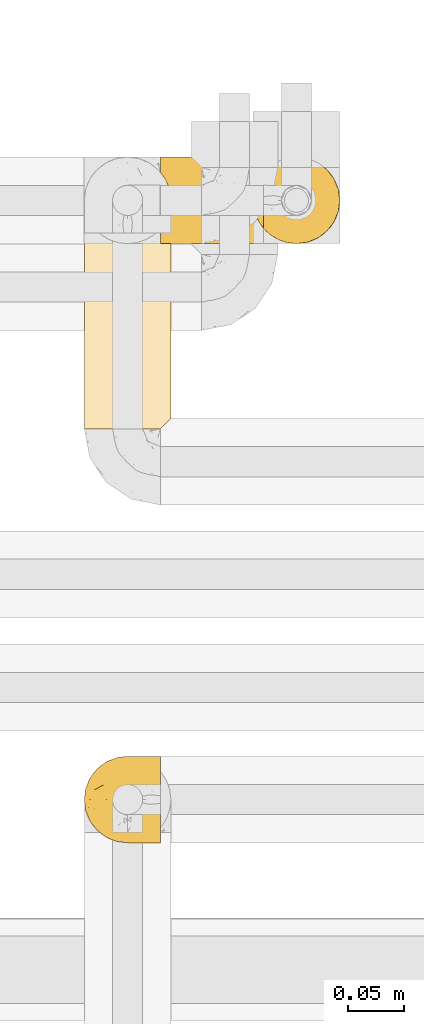
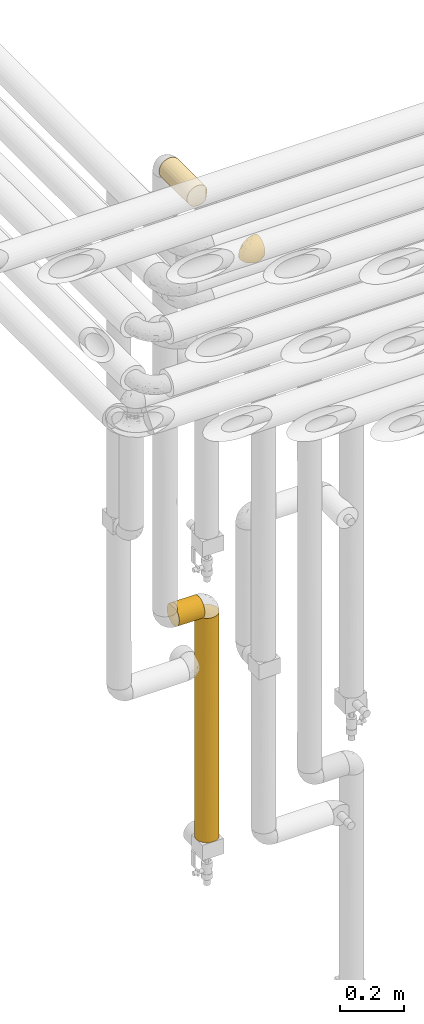
# One storey, part 291 of 827: 4 coverings.
"""IFC2X3 building model written with IfcOpenShell, lengths in millimetres."""

from ifc_helpers import new_model, entity, si_unit, converted_unit, derived_unit, direction, frame, origin, place, context, subcontext, project, spatial, faceted_brep, element, save


model = new_model("IFC2X3")

# Units and contexts
model_context = context("Model", 3, precision=0.01, world=origin(), true_north=direction((6.12303176911189e-17, 1.0)))
body_context = subcontext(model_context, "Body", "Model", "MODEL_VIEW")
ifc_project = project(units=[si_unit("LENGTHUNIT", "METRE", prefix="MILLI"), si_unit("AREAUNIT", "SQUARE_METRE"), si_unit("VOLUMEUNIT", "CUBIC_METRE"), converted_unit("PLANEANGLEUNIT", "DEGREE", entity("IfcRatioMeasure", 0.0174532925199433), si_unit("PLANEANGLEUNIT", "RADIAN"), dimensions=[0, 0, 0, 0, 0, 0, 0]), si_unit("MASSUNIT", "GRAM", prefix="KILO"), derived_unit("MASSDENSITYUNIT", [(si_unit("MASSUNIT", "GRAM", prefix="KILO"), 1), (si_unit("LENGTHUNIT", "METRE"), -3)]), derived_unit("MOMENTOFINERTIAUNIT", [(si_unit("LENGTHUNIT", "METRE"), 4)]), si_unit("TIMEUNIT", "SECOND"), si_unit("FREQUENCYUNIT", "HERTZ"), si_unit("THERMODYNAMICTEMPERATUREUNIT", "DEGREE_CELSIUS"), derived_unit("THERMALTRANSMITTANCEUNIT", [(si_unit("MASSUNIT", "GRAM", prefix="KILO"), 1), (si_unit("THERMODYNAMICTEMPERATUREUNIT", "KELVIN"), -1), (si_unit("TIMEUNIT", "SECOND"), -3)]), derived_unit("VOLUMETRICFLOWRATEUNIT", [(si_unit("LENGTHUNIT", "METRE"), 3), (si_unit("TIMEUNIT", "SECOND"), -1)]), derived_unit("MASSFLOWRATEUNIT", [(si_unit("MASSUNIT", "GRAM", prefix="KILO"), 1), (si_unit("TIMEUNIT", "SECOND"), -1)]), derived_unit("ROTATIONALFREQUENCYUNIT", [(si_unit("TIMEUNIT", "SECOND"), -1)]), si_unit("ELECTRICCURRENTUNIT", "AMPERE"), si_unit("ELECTRICVOLTAGEUNIT", "VOLT"), si_unit("POWERUNIT", "WATT"), si_unit("FORCEUNIT", "NEWTON", prefix="KILO"), si_unit("ILLUMINANCEUNIT", "LUX"), si_unit("LUMINOUSFLUXUNIT", "LUMEN"), si_unit("LUMINOUSINTENSITYUNIT", "CANDELA"), derived_unit("USERDEFINED", [(si_unit("MASSUNIT", "GRAM", prefix="KILO"), -1), (si_unit("LENGTHUNIT", "METRE"), -2), (si_unit("TIMEUNIT", "SECOND"), 3), (si_unit("LUMINOUSFLUXUNIT", "LUMEN"), 1)]), derived_unit("LINEARVELOCITYUNIT", [(si_unit("LENGTHUNIT", "METRE"), 1), (si_unit("TIMEUNIT", "SECOND"), -1)]), si_unit("PRESSUREUNIT", "PASCAL"), derived_unit("USERDEFINED", [(si_unit("LENGTHUNIT", "METRE"), -2), (si_unit("MASSUNIT", "GRAM", prefix="KILO"), 1), (si_unit("TIMEUNIT", "SECOND"), -2)]), derived_unit("LINEARFORCEUNIT", [(si_unit("MASSUNIT", "GRAM", prefix="KILO"), 1), (si_unit("LENGTHUNIT", "METRE"), 1), (si_unit("TIMEUNIT", "SECOND"), -2), (si_unit("LENGTHUNIT", "METRE"), -1)]), derived_unit("PLANARFORCEUNIT", [(si_unit("MASSUNIT", "GRAM", prefix="KILO"), 1), (si_unit("LENGTHUNIT", "METRE"), 1), (si_unit("TIMEUNIT", "SECOND"), -2), (si_unit("LENGTHUNIT", "METRE"), -2)])], contexts=[model_context])

# Site, building, storey
site_placement = place(None, origin())
site = spatial("IfcSite", under=ifc_project, at=site_placement, CompositionType="ELEMENT")
building_placement = place(site_placement, origin())
building = spatial("IfcBuilding", under=site, at=building_placement, CompositionType="ELEMENT")
storey_placement = place(building_placement, frame((0.0, 0.0, 28200.0)))
storey = spatial("IfcBuildingStorey", under=building, at=storey_placement, Name="08", CompositionType="ELEMENT", Elevation=28200.0)

# Coverings
covering_1_placement = place(storey_placement, frame((34952.84, 15249.95, 2969.3)))
element("IfcCovering", 1, at=covering_1_placement, inside=storey, Name=":ADSK_", ObjectType=":ADSK_", PredefinedType="INSULATION", context=body_context, shape_type="Brep", body=[
    faceted_brep([(69.15, 74.68, 47.38), (69.15, 70.1, 54.67), (69.15, 64.01, 60.76), (69.15, 56.72, 65.34), (69.15, 48.6, 68.18), (69.15, 40.05, 69.15), (69.15, 31.49, 68.18), (69.15, 23.36, 65.33), (69.15, 16.07, 60.75), (69.15, 9.98, 54.66), (69.15, 5.4, 47.37), (69.15, 2.56, 39.25), (69.15, 1.6, 30.7), (69.15, 2.46, 22.59), (69.15, 5.01, 14.86), (69.15, 9.13, 7.84), (69.15, 14.62, 1.85), (69.15, 16.82, 1.85), (69.15, 18.56, 1.85), (69.15, 20.52, 1.85), (69.15, 22.49, 1.85), (69.15, 24.46, 1.85), (69.15, 26.42, 1.85), (69.15, 28.39, 1.85), (69.15, 30.36, 1.85), (69.15, 32.55, 1.85), (69.15, 34.75, 1.85), (69.15, 36.94, 1.85), (69.15, 39.13, 1.85), (69.15, 41.33, 1.85), (69.15, 43.52, 1.85), (69.15, 45.72, 1.85), (69.15, 47.91, 1.85), (69.15, 50.11, 1.85), (69.15, 52.3, 1.85), (69.15, 54.49, 1.85), (69.15, 56.69, 1.85), (69.15, 58.88, 1.85), (69.15, 61.08, 1.85), (69.15, 63.27, 1.85), (69.15, 65.47, 1.85), (69.15, 70.97, 7.85), (69.15, 75.09, 14.88), (69.15, 77.64, 22.61), (69.15, 78.5, 30.7), (69.15, 77.53, 39.26), (68.89, 14.62, 1.6), (62.89, 9.12, 1.6), (55.87, 5.0, 1.6), (48.14, 2.46, 1.6), (40.05, 1.6, 1.6), (30.09, 2.91, 1.6), (20.82, 6.75, 1.6), (12.86, 12.86, 1.6), (6.75, 20.82, 1.6), (2.91, 30.09, 1.6), (1.6, 40.05, 1.6), (2.91, 50.0, 1.6), (6.75, 59.27, 1.6), (12.86, 67.23, 1.6), (20.82, 73.34, 1.6), (30.09, 77.19, 1.6), (40.05, 78.5, 1.6), (48.14, 77.63, 1.6), (55.87, 75.09, 1.6), (62.89, 70.97, 1.6), (68.89, 65.47, 1.6), (68.89, 63.27, 1.6), (68.89, 62.29, 1.6), (68.89, 60.7, 1.6), (68.89, 59.11, 1.6), (68.89, 57.52, 1.6), (68.89, 55.93, 1.6), (68.89, 54.34, 1.6), (68.89, 52.76, 1.6), (68.89, 51.17, 1.6), (68.89, 49.58, 1.6), (68.89, 47.99, 1.6), (68.89, 46.4, 1.6), (68.89, 44.81, 1.6), (68.89, 43.22, 1.6), (68.89, 41.63, 1.6), (68.89, 40.05, 1.6), (68.89, 38.46, 1.6), (68.89, 36.87, 1.6), (68.89, 35.28, 1.6), (68.89, 33.69, 1.6), (68.89, 32.1, 1.6), (68.89, 30.51, 1.6), (68.89, 28.92, 1.6), (68.89, 27.33, 1.6), (68.89, 25.37, 1.6), (68.89, 23.4, 1.6), (68.89, 21.21, 1.6), (68.89, 19.01, 1.6), (68.89, 16.82, 1.6), (68.97, 42.32, 1.78), (68.96, 44.02, 1.77), (68.97, 47.13, 1.78), (68.97, 48.74, 1.77), (68.98, 23.57, 1.79), (68.97, 25.13, 1.78), (68.96, 61.34, 1.76), (68.96, 22.02, 1.77), (68.96, 29.72, 1.77), (68.96, 56.73, 1.76), (68.96, 55.14, 1.77), (68.96, 37.66, 1.77), (69.0, 64.12, 1.8), (68.96, 28.13, 1.76), (68.96, 26.62, 1.77), (68.97, 31.46, 1.78), (68.96, 16.16, 1.77), (68.96, 39.16, 1.77), (68.96, 50.37, 1.76), (68.97, 17.69, 1.77), (68.97, 19.17, 1.78), (68.97, 62.78, 1.77), (68.96, 58.35, 1.77), (68.96, 45.53, 1.77), (68.97, 59.91, 1.78), (68.97, 65.47, 1.77), (69.02, 65.47, 1.8), (69.08, 65.47, 1.82), (68.97, 14.62, 1.77), (68.94, 14.62, 1.72), (68.92, 14.62, 1.66), (68.96, 20.59, 1.76), (68.96, 32.99, 1.77), (68.95, 34.48, 1.76), (68.96, 51.91, 1.77), (68.92, 65.47, 1.66), (68.94, 65.47, 1.72), (68.98, 53.48, 1.78), (69.08, 14.62, 1.82), (69.02, 14.62, 1.8), (68.96, 40.77, 1.77), (68.97, 35.97, 1.78), (61.33, 7.84, 3.72), (53.1, 3.53, 7.41), (63.33, 8.32, 6.13), (55.53, 2.19, 19.34), (63.33, 3.53, 17.64), (54.6, 1.6, 26.8), (41.99, 1.6, 8.87), (57.07, 4.57, 9.2), (57.95, 3.96, 12.79), (51.56, 2.28, 14.62), (41.58, 1.6, 7.34), (61.7, 7.69, 5.33), (65.0, 8.32, 7.7), (67.02, 7.84, 9.41), (61.87, 1.6, 28.75), (49.27, 1.6, 21.47), (43.94, 1.6, 16.15), (61.21, 4.34, 14.14), (63.4, 1.6, 29.16), (33.11, 29.63, 57.02), (52.82, 27.34, 64.92), (43.3, 40.05, 64.0), (33.73, 2.39, 11.92), (36.52, 2.43, 19.16), (24.87, 9.07, 28.65), (14.17, 16.64, 24.62), (18.43, 9.54, 15.19), (28.67, 4.52, 18.36), (26.0, 4.52, 9.2), (49.25, 7.49, 46.98), (59.72, 7.49, 50.24), (55.1, 12.85, 56.1), (44.72, 2.35, 28.97), (34.15, 22.66, 54.46), (5.25, 32.9, 21.34), (6.75, 25.33, 18.4), (55.54, 40.05, 66.44), (10.47, 16.64, 12.07), (25.49, 19.99, 45.49), (35.53, 16.37, 50.57), (48.22, 3.26, 36.04), (58.71, 3.75, 42.07), (57.42, 19.58, 62.12), (34.84, 7.5, 37.37), (36.87, 4.04, 29.39), (45.01, 13.94, 53.59), (44.4, 19.58, 58.06), (23.96, 28.21, 49.27), (11.2, 24.75, 29.63), (10.56, 31.42, 33.21), (16.81, 26.2, 40.1), (17.38, 33.36, 44.08), (21.38, 40.05, 49.36), (32.34, 40.05, 56.68), (4.3, 40.05, 15.2), (20.65, 16.14, 35.57), (29.66, 12.85, 41.7), (39.6, 10.47, 46.4), (42.55, 6.49, 41.41), (6.74, 40.05, 27.45), (14.06, 40.05, 38.4), (26.84, 75.57, 12.99), (5.28, 47.37, 21.33), (18.52, 52.91, 42.89), (33.13, 50.46, 57.04), (55.1, 67.23, 56.11), (57.43, 60.5, 62.13), (20.72, 70.55, 21.89), (11.46, 63.45, 16.62), (17.69, 62.61, 32.9), (49.26, 72.6, 46.99), (59.73, 72.6, 50.25), (58.71, 76.34, 42.08), (29.72, 59.34, 49.91), (35.35, 77.76, 15.6), (43.94, 78.5, 16.15), (41.99, 78.5, 8.87), (63.4, 78.5, 29.16), (4.93, 53.16, 13.16), (17.46, 70.55, 10.83), (10.94, 48.88, 33.8), (8.92, 54.76, 25.02), (52.83, 52.74, 64.92), (29.34, 71.93, 32.83), (30.26, 75.79, 20.56), (44.4, 60.5, 58.07), (39.06, 77.86, 21.46), (43.06, 77.64, 28.1), (54.6, 78.5, 26.8), (49.27, 78.5, 21.47), (42.69, 67.23, 51.29), (48.2, 76.82, 36.04), (61.87, 78.5, 28.75), (33.44, 77.8, 8.45), (29.67, 67.23, 41.73), (38.5, 73.2, 39.27), (23.35, 67.66, 33.56), (34.97, 75.99, 27.29), (53.1, 76.57, 7.41), (59.68, 73.21, 3.51), (62.19, 71.93, 4.68), (64.11, 71.07, 5.52), (57.97, 75.09, 8.75), (57.95, 76.13, 12.79), (63.33, 76.57, 17.65), (51.77, 77.69, 13.9), (67.02, 72.26, 9.42), (64.98, 71.77, 7.68), (55.53, 77.9, 19.33), (61.22, 75.75, 14.13)], [[[0, 1, 2, 3, 4, 5, 6, 7, 8, 9, 10, 11, 12, 13, 14, 15, 16, 17, 18, 19, 20, 21, 22, 23, 24, 25, 26, 27, 28, 29, 30, 31, 32, 33, 34, 35, 36, 37, 38, 39, 40, 41, 42, 43, 44, 45]], [[46, 47, 48, 49, 50, 51, 52, 53, 54, 55, 56, 57, 58, 59, 60, 61, 62, 63, 64, 65, 66, 67, 68, 69, 70, 71, 72, 73, 74, 75, 76, 77, 78, 79, 80, 81, 82, 83, 84, 85, 86, 87, 88, 89, 90, 91, 92, 93, 94, 95]], [[96, 97, 30]], [[98, 77, 99]], [[100, 101, 21]], [[69, 68, 102]], [[20, 19, 103]], [[24, 23, 104]], [[20, 103, 100]], [[72, 105, 106]], [[84, 83, 107]], [[89, 88, 104]], [[108, 67, 66]], [[109, 110, 90]], [[111, 25, 24]], [[112, 17, 16]], [[82, 113, 83]], [[109, 23, 22]], [[114, 76, 75]], [[105, 36, 106]], [[104, 111, 24]], [[18, 115, 116]], [[97, 96, 80]], [[67, 108, 117]], [[105, 71, 118]], [[31, 97, 119]], [[102, 120, 69]], [[108, 121, 122, 123, 40]], [[112, 95, 115]], [[17, 115, 18]], [[94, 116, 115]], [[117, 68, 67]], [[38, 117, 39]], [[112, 124, 125, 126, 46]], [[17, 112, 115]], [[70, 120, 118]], [[39, 117, 108]], [[120, 38, 37]], [[120, 37, 118]], [[120, 70, 69]], [[116, 94, 127]], [[128, 86, 129]], [[117, 38, 102]], [[74, 130, 75]], [[99, 33, 32]], [[115, 95, 94]], [[39, 108, 40]], [[108, 66, 131, 132, 121]], [[105, 72, 71]], [[118, 37, 36]], [[71, 70, 118]], [[35, 106, 36]], [[36, 105, 118]], [[35, 133, 106]], [[74, 73, 133]], [[106, 133, 73]], [[99, 114, 33]], [[133, 35, 34]], [[73, 72, 106]], [[95, 112, 46]], [[112, 16, 134, 135, 124]], [[130, 114, 75]], [[99, 76, 114]], [[114, 130, 33]], [[34, 33, 130]], [[78, 77, 98]], [[98, 119, 78]], [[130, 133, 34]], [[133, 130, 74]], [[79, 97, 80]], [[98, 99, 32]], [[98, 32, 31]], [[77, 76, 99]], [[97, 79, 119]], [[136, 96, 29]], [[30, 97, 31]], [[136, 29, 28]], [[81, 80, 96]], [[29, 96, 30]], [[31, 119, 98]], [[119, 79, 78]], [[96, 136, 81]], [[82, 81, 136]], [[113, 107, 83]], [[84, 107, 137]], [[107, 27, 137]], [[113, 28, 107]], [[27, 107, 28]], [[85, 84, 137]], [[137, 27, 26]], [[113, 136, 28]], [[136, 113, 82]], [[109, 89, 104]], [[86, 85, 129]], [[89, 109, 90]], [[111, 87, 128]], [[26, 129, 137]], [[88, 111, 104]], [[25, 111, 128]], [[22, 110, 109]], [[23, 109, 104]], [[110, 91, 90]], [[100, 92, 101]], [[110, 22, 101]], [[91, 110, 101]], [[116, 19, 18]], [[111, 88, 87]], [[127, 103, 19]], [[25, 128, 26]], [[86, 128, 87]], [[128, 129, 26]], [[137, 129, 85]], [[120, 102, 38]], [[117, 102, 68]], [[91, 101, 92]], [[21, 101, 22]], [[93, 92, 103]], [[100, 21, 20]], [[100, 103, 92]], [[127, 93, 103]], [[93, 127, 94]], [[116, 127, 19]], [[126, 138, 47]], [[48, 138, 139]], [[140, 125, 124]], [[141, 142, 143]], [[144, 49, 139]], [[145, 140, 146]], [[48, 139, 49]], [[139, 145, 147]], [[49, 144, 148, 50]], [[126, 125, 149]], [[14, 13, 142]], [[150, 146, 140]], [[149, 140, 145]], [[151, 150, 135]], [[151, 14, 142]], [[16, 15, 134]], [[13, 152, 142]], [[124, 150, 140]], [[141, 143, 153]], [[14, 151, 15]], [[15, 151, 134]], [[47, 46, 126]], [[139, 154, 144]], [[138, 48, 47]], [[125, 140, 149]], [[135, 134, 151]], [[146, 155, 141]], [[145, 146, 147]], [[149, 139, 138]], [[147, 153, 154]], [[147, 146, 141]], [[139, 147, 154]], [[139, 149, 145]], [[149, 138, 126]], [[147, 141, 153]], [[146, 150, 155]], [[151, 155, 150]], [[142, 141, 155]], [[13, 12, 156, 152]], [[152, 143, 142]], [[151, 142, 155]], [[150, 124, 135]], [[157, 158, 159]], [[160, 154, 161]], [[162, 163, 164]], [[165, 166, 160]], [[167, 168, 169]], [[153, 170, 161]], [[156, 12, 11]], [[158, 157, 171]], [[172, 55, 173]], [[158, 6, 174]], [[175, 54, 53]], [[52, 166, 164]], [[52, 164, 53]], [[54, 175, 173]], [[166, 52, 51]], [[176, 177, 171]], [[178, 143, 179]], [[156, 11, 179]], [[8, 7, 180]], [[169, 9, 8]], [[179, 143, 152, 156]], [[179, 11, 10]], [[168, 179, 10]], [[181, 162, 182]], [[179, 167, 178]], [[183, 184, 177]], [[183, 169, 184]], [[176, 171, 185]], [[172, 186, 187]], [[158, 7, 6]], [[159, 158, 174]], [[184, 180, 158]], [[54, 173, 55]], [[180, 169, 8]], [[188, 189, 187]], [[9, 168, 10]], [[186, 188, 187]], [[190, 157, 159, 191]], [[55, 172, 192]], [[176, 193, 194]], [[161, 170, 182]], [[162, 164, 165]], [[175, 164, 163]], [[51, 50, 148]], [[167, 195, 196]], [[178, 182, 170]], [[6, 5, 174]], [[158, 180, 7]], [[169, 180, 184]], [[169, 168, 9]], [[179, 168, 167]], [[182, 162, 165]], [[162, 194, 193]], [[161, 165, 160]], [[195, 181, 196]], [[192, 172, 197]], [[192, 56, 55]], [[189, 190, 198]], [[198, 197, 187]], [[172, 187, 197]], [[185, 189, 188]], [[198, 187, 189]], [[186, 172, 173]], [[173, 163, 186]], [[193, 186, 163]], [[176, 185, 188]], [[185, 157, 190]], [[188, 186, 193]], [[177, 176, 194]], [[188, 193, 176]], [[162, 193, 163]], [[195, 177, 194]], [[171, 177, 184]], [[181, 195, 194]], [[183, 167, 169]], [[162, 181, 194]], [[196, 182, 178]], [[158, 171, 184]], [[171, 157, 185]], [[177, 195, 183]], [[167, 183, 195]], [[182, 196, 181]], [[178, 170, 143]], [[178, 167, 196]], [[164, 175, 53]], [[173, 175, 163]], [[160, 51, 148]], [[164, 166, 165]], [[51, 160, 166]], [[160, 148, 144, 154]], [[153, 161, 154]], [[182, 165, 161]], [[190, 189, 185]], [[143, 170, 153]], [[60, 199, 61]], [[197, 200, 192]], [[201, 190, 202]], [[200, 57, 192]], [[203, 204, 2]], [[205, 206, 207]], [[208, 209, 210]], [[211, 207, 201]], [[212, 213, 214]], [[45, 215, 210]], [[216, 206, 58]], [[45, 44, 215]], [[59, 217, 60]], [[60, 217, 199]], [[0, 45, 210]], [[218, 201, 219]], [[202, 159, 220]], [[205, 221, 222]], [[223, 204, 203]], [[1, 203, 2]], [[57, 200, 216]], [[220, 3, 204]], [[220, 174, 4]], [[1, 0, 209]], [[212, 224, 213]], [[225, 226, 227]], [[228, 223, 203]], [[208, 210, 229]], [[210, 226, 229]], [[3, 220, 4]], [[58, 206, 59]], [[209, 203, 1]], [[202, 220, 223]], [[228, 203, 208]], [[202, 211, 201]], [[3, 2, 204]], [[202, 190, 191, 159]], [[210, 215, 230, 226]], [[199, 212, 231]], [[232, 233, 221]], [[233, 208, 229]], [[207, 206, 219]], [[217, 206, 205]], [[227, 224, 225]], [[233, 232, 228]], [[201, 207, 219]], [[234, 232, 221]], [[218, 219, 200]], [[202, 223, 211]], [[174, 220, 159]], [[174, 5, 4]], [[61, 231, 62]], [[220, 204, 223]], [[210, 209, 0]], [[203, 209, 208]], [[225, 233, 229]], [[224, 227, 213]], [[221, 233, 235]], [[57, 56, 192]], [[198, 218, 197]], [[200, 219, 216]], [[201, 198, 190]], [[197, 218, 200]], [[198, 201, 218]], [[206, 216, 219]], [[58, 57, 216]], [[231, 212, 214]], [[222, 212, 199]], [[228, 211, 223]], [[207, 211, 232]], [[62, 231, 214]], [[199, 231, 61]], [[233, 228, 208]], [[211, 228, 232]], [[222, 221, 235]], [[234, 205, 207]], [[206, 217, 59]], [[199, 217, 205]], [[205, 222, 199]], [[224, 222, 235]], [[222, 224, 212]], [[224, 235, 225]], [[233, 225, 235]], [[226, 225, 229]], [[205, 234, 221]], [[207, 232, 234]], [[63, 214, 236]], [[214, 213, 236]], [[214, 63, 62]], [[237, 236, 238]], [[238, 132, 131]], [[236, 237, 64]], [[239, 240, 241]], [[63, 236, 64]], [[131, 66, 65]], [[237, 131, 65]], [[242, 230, 43]], [[237, 65, 64]], [[239, 121, 132]], [[42, 242, 43]], [[241, 240, 243]], [[41, 123, 244]], [[43, 230, 215, 44]], [[244, 122, 245]], [[227, 246, 243]], [[245, 241, 247]], [[121, 239, 245]], [[41, 40, 123]], [[132, 238, 239]], [[244, 42, 41]], [[131, 237, 238]], [[240, 239, 238]], [[245, 239, 241]], [[247, 241, 246]], [[247, 244, 245]], [[238, 236, 240]], [[243, 236, 213]], [[236, 243, 240]], [[246, 241, 243]], [[243, 213, 227]], [[226, 242, 246]], [[227, 226, 246]], [[246, 242, 247]], [[244, 247, 242]], [[242, 226, 230]], [[42, 244, 242]], [[122, 244, 123]], [[122, 121, 245]]]),
])
covering_2_placement = place(storey_placement, frame((34952.89, 15617.54, 2960.0)))
element("IfcCovering", 2, at=covering_2_placement, inside=storey, Name=":ADSK_", ObjectType=":ADSK_", PredefinedType="INSULATION", context=body_context, shape_type="Brep", body=[
    faceted_brep([(20.8, 1.6, 6.74), (30.06, 1.6, 2.9), (40.0, 1.6, 1.6), (48.2, 1.6, 2.48), (56.01, 1.6, 5.09), (63.08, 1.6, 9.31), (69.1, 1.6, 14.94), (69.1, 1.6, 65.05), (63.08, 1.6, 70.68), (56.01, 1.6, 74.9), (48.2, 1.6, 77.51), (40.0, 1.6, 78.4), (30.06, 1.6, 77.09), (20.8, 1.6, 73.25), (12.84, 1.6, 67.15), (6.74, 1.6, 59.2), (2.9, 1.6, 49.93), (1.6, 1.6, 40.0), (2.9, 1.6, 30.06), (6.74, 1.6, 20.8), (12.84, 1.6, 12.84), (14.94, 175.4, 10.9), (9.31, 175.4, 16.91), (5.09, 175.4, 23.98), (2.48, 175.4, 31.79), (1.6, 175.4, 40.0), (2.9, 175.4, 49.93), (6.74, 175.4, 59.2), (12.84, 175.4, 67.15), (20.8, 175.4, 73.25), (30.06, 175.4, 77.09), (40.0, 175.4, 78.4), (49.93, 175.4, 77.09), (59.2, 175.4, 73.25), (67.15, 175.4, 67.15), (73.25, 175.4, 59.2), (77.09, 175.4, 49.93), (78.4, 175.4, 40.0), (77.51, 175.4, 31.79), (74.9, 175.4, 23.98), (70.68, 175.4, 16.91), (65.05, 175.4, 10.9), (20.48, 171.43, 6.92), (26.63, 168.5, 4.0), (33.21, 166.71, 2.2), (40.0, 166.1, 1.6), (46.78, 166.71, 2.2), (53.36, 168.5, 4.0), (59.51, 171.43, 6.92), (73.07, 5.57, 20.48), (76.0, 8.5, 26.63), (77.79, 10.29, 33.21), (78.4, 10.9, 40.0), (77.79, 10.29, 46.78), (76.0, 8.5, 53.36), (73.07, 5.57, 59.51)], [[[0, 1, 2, 3, 4, 5, 6, 7, 8, 9, 10, 11, 12, 13, 14, 15, 16, 17, 18, 19, 20]], [[21, 22, 23, 24, 25, 26, 27, 28, 29, 30, 31, 32, 33, 34, 35, 36, 37, 38, 39, 40, 41]], [[25, 24, 17]], [[24, 23, 18]], [[19, 23, 22]], [[18, 17, 24]], [[19, 18, 23]], [[22, 20, 19]], [[22, 21, 20]], [[21, 42, 0]], [[43, 44, 1]], [[42, 43, 0]], [[0, 43, 1]], [[2, 1, 44]], [[45, 2, 44]], [[21, 0, 20]], [[46, 47, 3]], [[48, 41, 5]], [[47, 48, 4]], [[45, 46, 2]], [[3, 2, 46]], [[47, 4, 3]], [[48, 5, 4]], [[41, 6, 5]], [[49, 40, 39]], [[50, 39, 38]], [[51, 38, 37]], [[49, 6, 40]], [[51, 50, 38]], [[52, 51, 37]], [[49, 39, 50]], [[40, 6, 41]], [[53, 52, 37]], [[53, 37, 36]], [[54, 36, 35]], [[54, 53, 36]], [[7, 55, 35]], [[54, 35, 55]], [[35, 34, 7]], [[8, 34, 33]], [[9, 33, 32]], [[10, 32, 31]], [[8, 33, 9]], [[9, 32, 10]], [[31, 11, 10]], [[34, 8, 7]], [[12, 11, 31, 30]], [[13, 12, 30, 29]], [[29, 28, 14, 13]], [[16, 15, 27, 26]], [[17, 16, 26, 25]], [[28, 27, 15, 14]], [[6, 49, 50, 51, 52, 53, 54, 55, 7]], [[47, 46, 45, 44, 43, 42, 21, 41, 48]]]),
])
covering_3_placement = place(storey_placement, frame((35102.89, 15782.05, 399.4)))
element("IfcCovering", 3, at=covering_3_placement, inside=storey, Name=":ADSK_", ObjectType=":ADSK_", PredefinedType="INSULATION", context=body_context, shape_type="Brep", body=[
    faceted_brep([(73.25, 20.8, 851.5), (77.09, 30.06, 851.5), (78.4, 40.0, 851.5), (77.09, 49.93, 851.5), (73.25, 59.2, 851.5), (67.15, 67.15, 851.5), (59.2, 73.25, 851.5), (49.93, 77.09, 851.5), (40.0, 78.4, 851.5), (31.79, 77.51, 851.5), (23.98, 74.9, 851.5), (16.91, 70.68, 851.5), (10.9, 65.05, 851.5), (10.9, 14.94, 851.5), (16.91, 9.31, 851.5), (23.98, 5.09, 851.5), (31.79, 2.48, 851.5), (40.0, 1.6, 851.5), (49.93, 2.9, 851.5), (59.2, 6.74, 851.5), (67.15, 12.84, 851.5), (78.4, 40.0, 1.6), (77.09, 30.06, 1.6), (73.25, 20.8, 1.6), (67.15, 12.84, 1.6), (59.2, 6.74, 1.6), (49.93, 2.9, 1.6), (40.0, 1.6, 1.6), (30.06, 2.9, 1.6), (20.8, 6.74, 1.6), (12.84, 12.84, 1.6), (6.74, 20.8, 1.6), (2.9, 30.06, 1.6), (1.6, 40.0, 1.6), (2.47, 48.16, 1.6), (5.06, 55.94, 1.6), (9.24, 62.99, 1.6), (14.82, 69.0, 1.6), (65.17, 69.0, 1.6), (70.75, 62.99, 1.6), (74.93, 55.94, 1.6), (77.52, 48.16, 1.6), (73.03, 59.58, 193.2), (76.43, 52.12, 260.4), (70.46, 63.37, 639.02), (46.82, 77.78, 10.38), (40.0, 78.4, 227.37), (50.26, 77.0, 318.6), (40.0, 78.4, 635.12), (78.4, 40.0, 217.97), (78.4, 40.0, 214.07), (68.12, 66.14, 250.4), (76.71, 51.24, 556.63), (78.4, 40.0, 434.34), (78.4, 40.0, 642.92), (65.07, 69.08, 640.06), (73.03, 59.58, 418.4), (59.61, 73.01, 5.61), (62.42, 71.17, 207.13), (57.17, 74.34, 327.55), (62.72, 70.95, 430.43), (53.43, 75.97, 8.57), (74.31, 57.23, 652.11), (78.4, 40.0, 426.55), (54.69, 75.47, 587.61), (68.98, 65.18, 448.78), (40.0, 78.4, 443.74), (47.22, 77.71, 539.43), (40.0, 78.4, 11.0), (78.4, 40.0, 635.12), (33.17, 77.78, 10.38), (2.2, 46.78, 842.8), (1.6, 40.0, 625.82), (1.6, 40.0, 842.2), (27.82, 76.41, 630.11), (20.3, 72.96, 643.26), (11.32, 65.53, 219.64), (23.21, 74.53, 423.84), (29.75, 77.0, 253.97), (23.32, 74.59, 190.29), (26.56, 75.97, 8.57), (13.75, 68.03, 606.3), (8.96, 62.61, 431.19), (6.75, 59.22, 237.93), (5.62, 57.1, 535.62), (6.92, 59.51, 847.52), (8.82, 62.42, 651.31), (13.6, 67.88, 401.51), (17.37, 71.02, 247.98), (20.38, 73.01, 5.61), (3.56, 52.12, 258.61), (2.98, 50.2, 535.61), (1.6, 40.0, 217.97), (1.6, 40.0, 409.45), (4.0, 53.36, 844.6), (4.52, 25.3, 266.47), (8.96, 17.38, 423.16), (5.61, 22.9, 526.2), (13.75, 11.96, 603.03), (20.33, 7.01, 660.07), (2.28, 32.78, 313.71), (10.89, 14.95, 213.7), (2.98, 29.79, 535.61), (4.0, 26.63, 844.6), (2.2, 33.21, 842.8), (14.71, 11.1, 403.4), (16.62, 9.53, 213.26), (8.75, 17.67, 646.19), (25.3, 4.52, 223.61), (32.5, 2.33, 206.99), (29.89, 2.95, 526.94), (20.33, 7.01, 434.72), (40.0, 1.6, 210.17), (40.0, 1.6, 217.97), (40.0, 1.6, 418.75), (40.0, 1.6, 635.12), (6.92, 20.48, 847.52), (63.37, 9.53, 426.55), (63.37, 9.53, 663.71), (54.69, 4.52, 564.96), (54.69, 4.52, 264.65), (63.37, 9.53, 189.38), (70.46, 16.62, 264.65), (75.42, 25.17, 190.73), (47.08, 2.26, 526.94), (46.86, 2.21, 290.07), (75.47, 25.3, 426.55), (70.46, 16.62, 564.96), (77.68, 32.64, 260.71), (75.78, 26.06, 655.62), (77.66, 32.5, 530.83)], [[[0, 1, 2, 3, 4, 5, 6, 7, 8, 9, 10, 11, 12, 13, 14, 15, 16, 17, 18, 19, 20]], [[21, 22, 23, 24, 25, 26, 27, 28, 29, 30, 31, 32, 33, 34, 35, 36, 37, 38, 39, 40, 41]], [[42, 43, 40]], [[5, 4, 44]], [[40, 39, 42]], [[45, 46, 47]], [[8, 7, 48]], [[41, 49, 50, 21]], [[43, 49, 41]], [[51, 39, 38]], [[52, 53, 43]], [[3, 54, 52]], [[5, 44, 55]], [[52, 43, 56]], [[38, 57, 58]], [[59, 60, 58]], [[61, 47, 59]], [[47, 61, 45]], [[40, 43, 41]], [[5, 55, 6]], [[3, 52, 62]], [[43, 53, 63, 49]], [[42, 51, 56]], [[60, 59, 64]], [[51, 60, 65]], [[66, 48, 67]], [[64, 7, 6]], [[56, 44, 62]], [[64, 6, 55]], [[60, 51, 58]], [[47, 66, 67]], [[56, 65, 44]], [[51, 42, 39]], [[43, 42, 56]], [[62, 44, 4]], [[56, 51, 65]], [[65, 55, 44]], [[55, 60, 64]], [[67, 7, 64]], [[7, 67, 48]], [[47, 67, 64]], [[38, 58, 51]], [[57, 61, 59]], [[59, 58, 57]], [[64, 59, 47]], [[3, 62, 4]], [[56, 62, 52]], [[46, 45, 68]], [[46, 66, 47]], [[54, 3, 2]], [[52, 54, 69, 53]], [[55, 65, 60]], [[68, 70, 46]], [[71, 72, 73]], [[10, 74, 75]], [[10, 9, 74]], [[76, 37, 36]], [[77, 78, 79]], [[78, 70, 80]], [[74, 9, 48]], [[12, 11, 81]], [[66, 74, 48]], [[80, 79, 78]], [[82, 76, 83]], [[77, 75, 74]], [[84, 85, 86]], [[86, 81, 82]], [[87, 77, 88]], [[37, 88, 89]], [[90, 91, 84]], [[34, 90, 35]], [[46, 70, 78]], [[34, 92, 90]], [[91, 72, 71]], [[90, 92, 93]], [[81, 86, 12]], [[88, 79, 89]], [[75, 77, 87]], [[94, 91, 71]], [[90, 84, 83]], [[94, 85, 84]], [[76, 82, 87]], [[78, 77, 74]], [[82, 81, 87]], [[75, 81, 11]], [[46, 78, 66]], [[34, 33, 92]], [[9, 8, 48]], [[66, 78, 74]], [[93, 91, 90]], [[10, 75, 11]], [[84, 86, 82]], [[12, 86, 85]], [[84, 82, 83]], [[94, 84, 91]], [[91, 93, 72]], [[37, 76, 88]], [[36, 35, 83]], [[36, 83, 76]], [[35, 90, 83]], [[87, 81, 75]], [[88, 76, 87]], [[89, 79, 80]], [[77, 79, 88]], [[95, 96, 97]], [[98, 99, 14]], [[100, 93, 92]], [[95, 31, 101]], [[102, 93, 100]], [[102, 103, 104]], [[31, 95, 32]], [[98, 96, 105]], [[30, 29, 106]], [[103, 102, 97]], [[30, 101, 31]], [[104, 72, 102]], [[98, 107, 96]], [[15, 14, 99]], [[108, 109, 110]], [[111, 105, 106]], [[109, 27, 112, 113, 114]], [[114, 115, 110]], [[111, 106, 108]], [[98, 14, 13]], [[29, 28, 108]], [[106, 101, 30]], [[97, 96, 107]], [[16, 115, 17]], [[16, 15, 110]], [[33, 32, 92]], [[15, 99, 110]], [[107, 13, 116]], [[99, 98, 111]], [[16, 110, 115]], [[110, 99, 111]], [[28, 109, 108]], [[110, 111, 108]], [[114, 110, 109]], [[108, 106, 29]], [[111, 98, 105]], [[105, 101, 106]], [[101, 96, 95]], [[100, 32, 95]], [[32, 100, 92]], [[102, 100, 95]], [[27, 109, 28]], [[13, 107, 98]], [[116, 103, 97]], [[97, 107, 116]], [[95, 97, 102]], [[72, 104, 73]], [[72, 93, 102]], [[101, 105, 96]], [[117, 118, 119, 120, 121]], [[122, 23, 123]], [[124, 114, 125]], [[25, 120, 26]], [[26, 125, 112]], [[24, 121, 25]], [[114, 124, 115]], [[118, 20, 19]], [[19, 18, 119]], [[126, 127, 122]], [[117, 121, 122, 127, 118]], [[22, 128, 123]], [[129, 127, 126]], [[128, 21, 50, 49, 63]], [[118, 127, 20]], [[23, 122, 24]], [[18, 115, 124]], [[0, 20, 127]], [[1, 69, 54, 2]], [[126, 130, 129]], [[124, 125, 120]], [[63, 130, 128]], [[120, 25, 121]], [[1, 129, 130]], [[18, 17, 115]], [[112, 27, 26]], [[120, 119, 124]], [[18, 124, 119]], [[26, 120, 125]], [[1, 130, 69]], [[130, 63, 53, 69]], [[126, 123, 128]], [[126, 128, 130]], [[21, 128, 22]], [[1, 0, 129]], [[127, 129, 0]], [[125, 114, 113, 112]], [[122, 123, 126]], [[22, 123, 23]], [[119, 118, 19]], [[122, 121, 24]], [[104, 103, 116, 13, 12, 85, 94, 71, 73]], [[89, 80, 70, 68, 45, 61, 57, 38, 37]]]),
])
covering_4_placement = place(storey_placement, frame((35020.39, 15782.05, 1240.0)))
element("IfcCovering", 4, at=covering_4_placement, inside=storey, Name=":ADSK_", ObjectType=":ADSK_", PredefinedType="INSULATION", context=body_context, shape_type="Brep", body=[
    faceted_brep([(93.4, 77.51, 31.79), (93.4, 78.4, 40.0), (93.4, 77.09, 49.93), (93.4, 73.25, 59.2), (93.4, 67.15, 67.15), (93.4, 59.2, 73.25), (93.4, 49.93, 77.09), (93.4, 40.0, 78.4), (93.4, 30.06, 77.09), (93.4, 20.8, 73.25), (93.4, 12.84, 67.15), (93.4, 6.74, 59.2), (93.4, 2.9, 49.93), (93.4, 1.6, 40.0), (93.4, 2.48, 31.79), (93.4, 5.09, 23.98), (93.4, 9.31, 16.91), (93.4, 14.94, 10.9), (93.4, 65.05, 10.9), (93.4, 70.68, 16.91), (93.4, 74.9, 23.98), (1.6, 77.09, 30.06), (1.6, 73.25, 20.8), (1.6, 67.15, 12.84), (1.6, 59.2, 6.74), (1.6, 49.93, 2.9), (1.6, 40.0, 1.6), (1.6, 30.06, 2.9), (1.6, 20.8, 6.74), (1.6, 12.84, 12.84), (1.6, 6.74, 20.8), (1.6, 2.9, 30.06), (1.6, 1.6, 40.0), (1.6, 2.48, 48.2), (1.6, 5.09, 56.01), (1.6, 9.31, 63.08), (1.6, 14.94, 69.1), (1.6, 65.05, 69.1), (1.6, 70.68, 63.08), (1.6, 74.9, 56.01), (1.6, 77.51, 48.2), (1.6, 78.4, 40.0), (86.5, 26.63, 4.0), (84.7, 33.21, 2.2), (84.1, 40.0, 1.6), (89.42, 20.48, 6.92), (84.7, 46.78, 2.2), (86.5, 53.36, 4.0), (89.42, 59.51, 6.92), (5.57, 59.51, 73.07), (8.5, 53.36, 76.0), (10.29, 46.78, 77.79), (10.9, 40.0, 78.4), (10.29, 33.21, 77.79), (8.5, 26.63, 76.0), (5.57, 20.48, 73.07)], [[[0, 1, 2, 3, 4, 5, 6, 7, 8, 9, 10, 11, 12, 13, 14, 15, 16, 17, 18, 19, 20]], [[21, 22, 23, 24, 25, 26, 27, 28, 29, 30, 31, 32, 33, 34, 35, 36, 37, 38, 39, 40, 41]], [[32, 31, 14]], [[30, 29, 16]], [[31, 30, 15]], [[14, 13, 32]], [[16, 15, 30]], [[14, 31, 15]], [[29, 17, 16]], [[42, 28, 27]], [[27, 26, 43]], [[44, 43, 26]], [[45, 17, 28]], [[43, 42, 27]], [[45, 28, 42]], [[28, 17, 29]], [[46, 44, 26]], [[46, 26, 25]], [[47, 25, 24]], [[47, 46, 25]], [[18, 48, 24]], [[47, 24, 48]], [[24, 23, 18]], [[19, 23, 22]], [[20, 22, 21]], [[0, 21, 41]], [[19, 22, 20]], [[20, 21, 0]], [[41, 1, 0]], [[23, 19, 18]], [[1, 41, 40]], [[2, 40, 39]], [[3, 39, 38]], [[1, 40, 2]], [[2, 39, 3]], [[38, 4, 3]], [[38, 37, 4]], [[37, 49, 5]], [[50, 51, 6]], [[49, 50, 5]], [[5, 50, 6]], [[7, 6, 51]], [[52, 7, 51]], [[37, 5, 4]], [[53, 54, 8]], [[55, 36, 9]], [[54, 55, 9]], [[52, 53, 7]], [[7, 53, 8]], [[54, 9, 8]], [[36, 10, 9]], [[11, 35, 34]], [[12, 34, 33]], [[13, 33, 32]], [[10, 35, 11]], [[11, 34, 12]], [[33, 13, 12]], [[35, 10, 36]], [[43, 44, 46, 47, 48, 18, 17, 45, 42]], [[36, 55, 54, 53, 52, 51, 50, 49, 37]]]),
])

save(model, "model.ifc")
